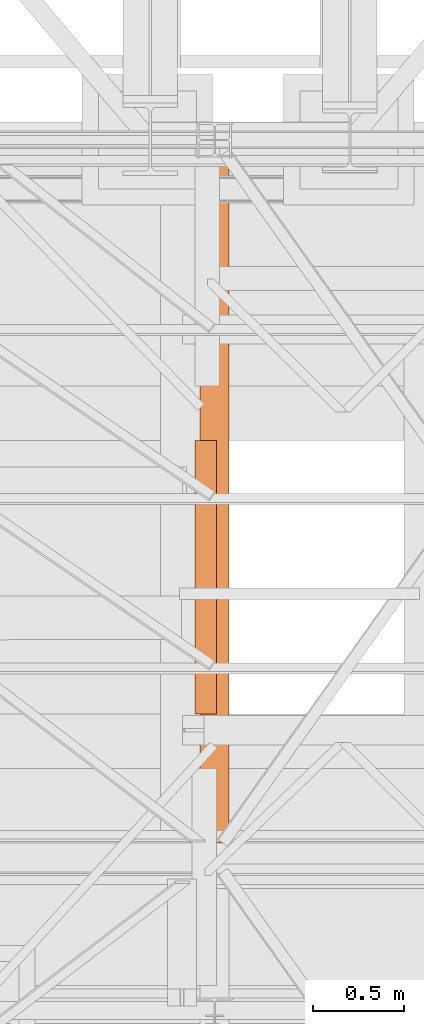
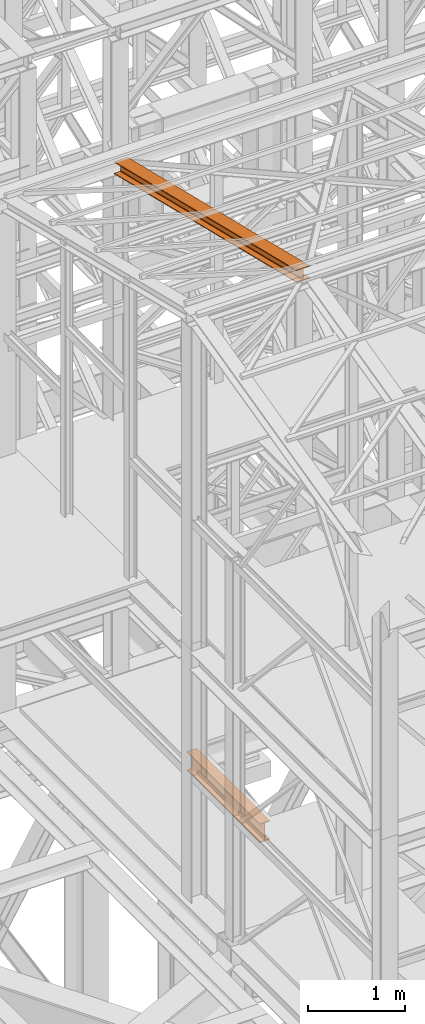
# One storey, part 28 of 208: 2 proxies.
"""IFC2X3 building model written with IfcOpenShell, lengths in millimetres."""

from ifc_helpers import new_model, entity, si_unit, converted_unit, frame, origin, origin_with_axes, place, context, subcontext, project, spatial, faceted_brep, element, save


model = new_model("IFC2X3")

# Units and contexts
model_context = context("Model", 3, precision=1e-05, world=origin())
plan_context = context("Plan", 3, precision=1e-05, world=origin())
body_context = subcontext(model_context, "Body", "Model", "MODEL_VIEW")
ifc_project = project(units=[si_unit("LENGTHUNIT", "METRE", prefix="MILLI"), converted_unit("PLANEANGLEUNIT", "DEGREE", entity("IfcPlaneAngleMeasure", 0.0174532925199433), si_unit("PLANEANGLEUNIT", "RADIAN"), dimensions=[0, 0, 0, 0, 0, 0, 0]), si_unit("AREAUNIT", "SQUARE_METRE"), si_unit("VOLUMEUNIT", "CUBIC_METRE")], contexts=[model_context, plan_context])

# Building, storey
building_placement = place(None, origin())
building = spatial("IfcBuilding", under=ifc_project, at=building_placement, CompositionType="COMPLEX")
storey_placement = place(building_placement, origin_with_axes())
storey = spatial("IfcBuildingStorey", under=building, at=storey_placement, Name="Geschoss", CompositionType="ELEMENT")

# Proxies
proxy_1_placement = place(storey_placement, frame((2468.254966591507, -21137.57438465545, 11628.70515179705), z_axis=(0.0, 0.0, 1.0), x_axis=(1.0, 0.0, 0.0)))
element("IfcBuildingElementProxy", 1, at=proxy_1_placement, inside=storey, context=body_context, shape_type="Brep", body=[
    faceted_brep([(160.0100113248891, 0.01000000000203727, 1074.775244917653), (0.01000000000567525, 0.01000000000203727, 1074.775244917653), (0.01000000000021828, 3780.009979404025, 156.4315054631916), (160.01001132488, 3780.009979404025, 156.4315054631916), (0.01000000000567525, 0.01000000000203727, 1074.775244917653), (0.01000000000567525, 0.01000000000203727, 1065.513442427271), (0.01000000000021828, 3780.009979404025, 147.1697029728093), (0.01000000000021828, 3780.009979404025, 156.4315054631916), (0.01000000000567525, 0.01000000000203727, 1065.513442427271), (62.01000457466125, 0.01000000000203727, 1065.513442427271), (62.01000457465671, 3780.009979404025, 147.1697029728093), (0.01000000000021828, 3780.009979404025, 147.1697029728093), (62.01000457466125, 0.01000000000203727, 1065.513442427271), (69.77318079978704, 0.01000000000203727, 1063.914455819968), (69.77318079977886, 3780.009979404025, 145.5707163655079), (62.01000457465671, 3780.009979404025, 147.1697029728093), (69.77318079978704, 0.01000000000203727, 1063.914455819968), (75.45621545821996, 0.01000000000203727, 1058.066108594254), (75.45621545821086, 3780.009979404025, 139.7223691397903), (69.77318079977886, 3780.009979404025, 145.5707163655079), (75.45621545821996, 0.01000000000203727, 1058.066108594254), (77.01000563636899, 0.01000000000203727, 1050.077113888498), (77.0100056363608, 3780.009979404025, 131.7333744340358), (75.45621545821086, 3780.009979404025, 139.7223691397903), (77.01000563636899, 0.01000000000203727, 1050.077113888498), (77.01000563636899, 0.01000000000203727, 943.0518743172743), (77.0100056363608, 3780.009979404025, 24.70813486281259), (77.0100056363608, 3780.009979404025, 131.7333744340358), (77.01000563636899, 0.01000000000203727, 943.0518743172743), (75.45621545821905, 0.01000000000203727, 935.0628757778613), (75.45621545821086, 3780.009979404025, 16.71913632339965), (77.0100056363608, 3780.009979404025, 24.70813486281259), (75.45621545821905, 0.01000000000203727, 935.0628757778613), (69.77318079978704, 0.01000000000203727, 929.2145285521474), (69.77318079977886, 3780.009979404025, 10.87078909768752), (75.45621545821086, 3780.009979404025, 16.71913632339965), (69.77318079978704, 0.01000000000203727, 929.2145285521474), (62.01000457466125, 0.01000000000203727, 927.6155419448442), (62.01000457465307, 3780.009979404025, 9.27180249038247), (69.77318079977886, 3780.009979404025, 10.87078909768752), (62.01000457466125, 0.01000000000203727, 927.6155419448442), (0.01000000000567525, 0.01000000000203727, 927.6155419448423), (0.01000000000021828, 3780.009979404025, 9.27180249038247), (62.01000457465307, 3780.009979404025, 9.27180249038247), (0.01000000000567525, 0.01000000000203727, 927.6155419448423), (0.01000000000476575, 0.01000000000203727, 918.3537394544601), (0.01000000000021828, 3780.009979404025, 0.01000000000021828), (0.01000000000021828, 3780.009979404025, 9.27180249038247), (0.01000000000476575, 0.01000000000203727, 918.3537394544601), (160.0100113248891, 0.01000000000203727, 918.3537394544619), (160.0100113248827, 3780.009979404025, 0.01000000000021828), (0.01000000000021828, 3780.009979404025, 0.01000000000021828), (160.0100113248891, 0.01000000000203727, 918.3537394544619), (160.0100113248891, 0.01000000000203727, 927.6155419448423), (160.0100113248836, 3780.009979404025, 9.27180249038065), (160.0100113248827, 3780.009979404025, 0.01000000000021828), (160.0100113248891, 0.01000000000203727, 927.6155419448423), (98.01000675023079, 0.01000000000203727, 927.6155419448423), (98.0100067502226, 3780.009979404025, 9.27180249038247), (160.0100113248836, 3780.009979404025, 9.27180249038065), (98.01000675023079, 0.01000000000203727, 927.6155419448423), (90.246830525105, 0.01000000000203727, 929.2145285521474), (90.24683052509681, 3780.009979404025, 10.87078909768752), (98.0100067502226, 3780.009979404025, 9.27180249038247), (90.246830525105, 0.01000000000203727, 929.2145285521474), (84.56379586667299, 0.01000000000203727, 935.0628757778613), (84.5637958666648, 3780.009979404025, 16.71913632339783), (90.24683052509681, 3780.009979404025, 10.87078909768752), (84.56379586667299, 0.01000000000203727, 935.0628757778613), (83.01000568852305, 0.01000000000203727, 943.0518743172743), (83.01000568851487, 3780.009979404025, 24.70813486281077), (84.5637958666648, 3780.009979404025, 16.71913632339783), (83.01000568852305, 0.01000000000203727, 943.0518743172743), (83.01000568852305, 0.01000000000203727, 1050.077113888496), (83.01000568851487, 3780.009979404025, 131.733374434034), (83.01000568851487, 3780.009979404025, 24.70813486281077), (83.01000568852305, 0.01000000000203727, 1050.077113888496), (84.5637958666739, 0.01000000000203727, 1058.066108594254), (84.5637958666648, 3780.009979404025, 139.7223691397903), (83.01000568851487, 3780.009979404025, 131.733374434034), (84.5637958666739, 0.01000000000203727, 1058.066108594254), (90.2468305251059, 0.01000000000203727, 1063.914455819968), (90.24683052509681, 3780.009979404025, 145.5707163655079), (84.5637958666648, 3780.009979404025, 139.7223691397903), (90.2468305251059, 0.01000000000203727, 1063.914455819968), (98.01000675023079, 0.01000000000203727, 1065.513442427271), (98.0100067502226, 3780.009979404025, 147.1697029728093), (90.24683052509681, 3780.009979404025, 145.5707163655079), (98.01000675023079, 0.01000000000203727, 1065.513442427271), (160.0100113248891, 0.01000000000203727, 1065.513442427271), (160.0100113248827, 3780.009979404025, 147.1697029728093), (98.0100067502226, 3780.009979404025, 147.1697029728093), (160.0100113248891, 0.01000000000203727, 1065.513442427271), (160.0100113248891, 0.01000000000203727, 1074.775244917653), (160.01001132488, 3780.009979404025, 156.4315054631916), (160.0100113248827, 3780.009979404025, 147.1697029728093), (0.01000000000567525, 0.01000000000203727, 1074.775244917653), (160.0100113248891, 0.01000000000203727, 1074.775244917653), (160.0100113248891, 0.01000000000203727, 1065.513442427271), (98.01000675023079, 0.01000000000203727, 1065.513442427271), (90.2468305251059, 0.01000000000203727, 1063.914455819968), (84.5637958666739, 0.01000000000203727, 1058.066108594254), (83.01000568852305, 0.01000000000203727, 1050.077113888496), (83.01000568852305, 0.01000000000203727, 943.0518743172743), (84.56379586667299, 0.01000000000203727, 935.0628757778613), (90.246830525105, 0.01000000000203727, 929.2145285521474), (98.01000675023079, 0.01000000000203727, 927.6155419448423), (160.0100113248891, 0.01000000000203727, 927.6155419448423), (160.0100113248891, 0.01000000000203727, 918.3537394544619), (0.01000000000476575, 0.01000000000203727, 918.3537394544601), (0.01000000000567525, 0.01000000000203727, 927.6155419448423), (62.01000457466125, 0.01000000000203727, 927.6155419448442), (69.77318079978704, 0.01000000000203727, 929.2145285521474), (75.45621545821905, 0.01000000000203727, 935.0628757778613), (77.01000563636899, 0.01000000000203727, 943.0518743172743), (77.01000563636899, 0.01000000000203727, 1050.077113888498), (75.45621545821996, 0.01000000000203727, 1058.066108594254), (69.77318079978704, 0.01000000000203727, 1063.914455819968), (62.01000457466125, 0.01000000000203727, 1065.513442427271), (0.01000000000567525, 0.01000000000203727, 1065.513442427271), (160.01001132488, 3780.009979404025, 156.4315054631916), (0.01000000000021828, 3780.009979404025, 156.4315054631916), (0.01000000000021828, 3780.009979404025, 147.1697029728093), (62.01000457465671, 3780.009979404025, 147.1697029728093), (69.77318079977886, 3780.009979404025, 145.5707163655079), (75.45621545821086, 3780.009979404025, 139.7223691397903), (77.0100056363608, 3780.009979404025, 131.7333744340358), (77.0100056363608, 3780.009979404025, 24.70813486281259), (75.45621545821086, 3780.009979404025, 16.71913632339965), (69.77318079977886, 3780.009979404025, 10.87078909768752), (62.01000457465307, 3780.009979404025, 9.27180249038247), (0.01000000000021828, 3780.009979404025, 9.27180249038247), (0.01000000000021828, 3780.009979404025, 0.01000000000021828), (160.0100113248827, 3780.009979404025, 0.01000000000021828), (160.0100113248836, 3780.009979404025, 9.27180249038065), (98.0100067502226, 3780.009979404025, 9.27180249038247), (90.24683052509681, 3780.009979404025, 10.87078909768752), (84.5637958666648, 3780.009979404025, 16.71913632339783), (83.01000568851487, 3780.009979404025, 24.70813486281077), (83.01000568851487, 3780.009979404025, 131.733374434034), (84.5637958666648, 3780.009979404025, 139.7223691397903), (90.24683052509681, 3780.009979404025, 145.5707163655079), (98.0100067502226, 3780.009979404025, 147.1697029728093), (160.0100113248827, 3780.009979404025, 147.1697029728093)], [[[0, 1, 2, 3]], [[4, 5, 6, 7]], [[8, 9, 10, 11]], [[12, 13, 14, 15]], [[16, 17, 18, 19]], [[20, 21, 22, 23]], [[24, 25, 26, 27]], [[28, 29, 30, 31]], [[32, 33, 34, 35]], [[36, 37, 38, 39]], [[40, 41, 42, 43]], [[44, 45, 46, 47]], [[48, 49, 50, 51]], [[52, 53, 54, 55]], [[56, 57, 58, 59]], [[60, 61, 62, 63]], [[64, 65, 66, 67]], [[68, 69, 70, 71]], [[72, 73, 74, 75]], [[76, 77, 78, 79]], [[80, 81, 82, 83]], [[84, 85, 86, 87]], [[88, 89, 90, 91]], [[92, 93, 94, 95]], [[96, 97, 98, 99, 100, 101, 102, 103, 104, 105, 106, 107, 108, 109, 110, 111, 112, 113, 114, 115, 116, 117, 118, 119]], [[120, 121, 122, 123, 124, 125, 126, 127, 128, 129, 130, 131, 132, 133, 134, 135, 136, 137, 138, 139, 140, 141, 142, 143]]], orient=[[False], [False], [False], [False], [False], [False], [False], [False], [False], [False], [False], [False], [False], [False], [False], [False], [False], [False], [False], [False], [False], [False], [False], [False], [False], [False]]),
])
proxy_2_placement = place(storey_placement, frame((2438.254968338675, -20428.57439012789, 5044.990005364415), z_axis=(0.0, 0.0, 1.0), x_axis=(1.0, 0.0, 0.0)))
element("IfcBuildingElementProxy", 2, at=proxy_2_placement, inside=storey, context=body_context, shape_type="Brep", body=[
    faceted_brep([(120.0100000000002, 1510.009999999998, 0.01000000000021828), (120.0100000000002, 0.00999999999839929, 0.01000000000021828), (120.0100000000002, 0.00999999999839929, 9.810000190735991), (120.0100000000002, 1510.009999999998, 9.810000190735082), (120.0100000000002, 1510.009999999998, 9.810000190735082), (120.0100000000002, 0.00999999999839929, 9.810000190735991), (78.10999990463279, 0.00999999999839929, 9.810000190735082), (78.10999990463279, 1510.009999999998, 9.810000190735082), (78.10999990463279, 1510.009999999998, 9.810000190735082), (78.10999990463279, 0.00999999999839929, 9.810000190735082), (74.22772724864444, 0.00999999999839929, 10.32115675322984), (74.22772724864444, 1510.009999999998, 10.32115675323075), (74.22772724864444, 1510.009999999998, 10.32115675323075), (74.22772724864444, 0.00999999999839929, 10.32115675322984), (70.61002177988667, 0.00999999999839929, 11.81965942306215), (70.61002177988667, 1510.009999999998, 11.81965942306215), (70.61002177988667, 1510.009999999998, 11.81965942306215), (70.61002177988667, 0.00999999999839929, 11.81965942306215), (67.5033981868346, 0.00999999999839929, 14.2033984729369), (67.5033981868346, 1510.009999999998, 14.2033984729369), (67.5033981868346, 1510.009999999998, 14.2033984729369), (67.5033981868346, 0.00999999999839929, 14.2033984729369), (65.11965913696076, 0.00999999999839929, 17.31002206598896), (65.11965913696076, 1510.009999999998, 17.31002206598896), (65.11965913696076, 1510.009999999998, 17.31002206598896), (65.11965913696076, 0.00999999999839929, 17.31002206598896), (63.62115646713028, 0.00999999999839929, 20.92772753474765), (63.62115646713028, 1510.009999999998, 20.92772753474765), (63.62115646713028, 1510.009999999998, 20.92772753474765), (63.62115646713028, 0.00999999999839929, 20.92772753474765), (63.10999990463279, 0.00999999999839929, 24.81000019073599), (63.10999990463279, 1510.009999999998, 24.81000019073508), (63.10999990463279, 1510.009999999998, 24.81000019073508), (63.10999990463279, 0.00999999999839929, 24.81000019073599), (63.10999990463279, 0.00999999999839929, 215.2099998092654), (63.10999990463279, 1510.009999999998, 215.2099998092654), (63.10999990463279, 1510.009999999998, 215.2099998092654), (63.10999990463279, 0.00999999999839929, 215.2099998092654), (63.62115646713028, 0.00999999999839929, 219.0922724652528), (63.62115646713028, 1510.009999999998, 219.0922724652519), (63.62115646713028, 1510.009999999998, 219.0922724652519), (63.62115646713028, 0.00999999999839929, 219.0922724652528), (65.11965913695985, 0.00999999999839929, 222.7099779340106), (65.11965913696076, 1510.009999999998, 222.7099779340106), (65.11965913696076, 1510.009999999998, 222.7099779340106), (65.11965913695985, 0.00999999999839929, 222.7099779340106), (67.5033981868346, 0.00999999999839929, 225.8166015270635), (67.5033981868346, 1510.009999999998, 225.8166015270635), (67.5033981868346, 1510.009999999998, 225.8166015270635), (67.5033981868346, 0.00999999999839929, 225.8166015270635), (70.61002177988667, 0.00999999999839929, 228.2003405769374), (70.61002177988667, 1510.009999999998, 228.2003405769374), (70.61002177988667, 1510.009999999998, 228.2003405769374), (70.61002177988667, 0.00999999999839929, 228.2003405769374), (74.22772724864444, 0.00999999999839929, 229.6988432467688), (74.22772724864444, 1510.009999999998, 229.6988432467688), (74.22772724864444, 1510.009999999998, 229.6988432467688), (74.22772724864444, 0.00999999999839929, 229.6988432467688), (78.10999990463279, 0.00999999999839929, 230.2099998092654), (78.10999990463279, 1510.009999999998, 230.2099998092654), (78.10999990463279, 1510.009999999998, 230.2099998092654), (78.10999990463279, 0.00999999999839929, 230.2099998092654), (120.0100000000002, 0.00999999999839929, 230.2099998092654), (120.0100000000002, 1510.009999999998, 230.2099998092654), (120.0100000000002, 1510.009999999998, 230.2099998092654), (120.0100000000002, 0.00999999999839929, 230.2099998092654), (120.0100000000002, 0.00999999999839929, 240.0100000000002), (120.0100000000002, 1510.009999999998, 240.0100000000002), (120.0100000000002, 1510.009999999998, 240.0100000000002), (120.0100000000002, 0.00999999999839929, 240.0100000000002), (0.01000000000021828, 0.00999999999839929, 240.0100000000002), (0.01000000000021828, 1510.009999999998, 240.0100000000002), (0.01000000000021828, 1510.009999999998, 240.0100000000002), (0.01000000000021828, 0.00999999999839929, 240.0100000000002), (0.01000000000021828, 0.00999999999839929, 230.2099998092654), (0.01000000000021828, 1510.009999999998, 230.2099998092654), (0.01000000000021828, 1510.009999999998, 230.2099998092654), (0.01000000000021828, 0.00999999999839929, 230.2099998092654), (41.91000009536765, 0.00999999999839929, 230.2099998092654), (41.91000009536765, 1510.009999999998, 230.2099998092654), (41.91000009536765, 1510.009999999998, 230.2099998092654), (41.91000009536765, 0.00999999999839929, 230.2099998092654), (45.792272751356, 0.00999999999839929, 229.6988432467688), (45.792272751356, 1510.009999999998, 229.6988432467688), (45.792272751356, 1510.009999999998, 229.6988432467688), (45.792272751356, 0.00999999999839929, 229.6988432467688), (49.40997822011377, 0.00999999999839929, 228.2003405769374), (49.40997822011377, 1510.009999999998, 228.2003405769374), (49.40997822011377, 1510.009999999998, 228.2003405769374), (49.40997822011377, 0.00999999999839929, 228.2003405769374), (52.51660181316584, 0.00999999999839929, 225.8166015270635), (52.51660181316584, 1510.009999999998, 225.8166015270635), (52.51660181316584, 1510.009999999998, 225.8166015270635), (52.51660181316584, 0.00999999999839929, 225.8166015270635), (54.90034086303967, 0.00999999999839929, 222.7099779340106), (54.90034086303967, 1510.009999999998, 222.7099779340106), (54.90034086303967, 1510.009999999998, 222.7099779340106), (54.90034086303967, 0.00999999999839929, 222.7099779340106), (56.39884353287016, 0.00999999999839929, 219.0922724652519), (56.39884353287016, 1510.009999999998, 219.0922724652519), (56.39884353287016, 1510.009999999998, 219.0922724652519), (56.39884353287016, 0.00999999999839929, 219.0922724652519), (56.91000009536765, 0.00999999999839929, 215.2099998092654), (56.91000009536765, 1510.009999999998, 215.2099998092654), (56.91000009536765, 1510.009999999998, 215.2099998092654), (56.91000009536765, 0.00999999999839929, 215.2099998092654), (56.91000009536765, 0.00999999999839929, 24.81000019073599), (56.91000009536765, 1510.009999999998, 24.81000019073508), (56.91000009536765, 1510.009999999998, 24.81000019073508), (56.91000009536765, 0.00999999999839929, 24.81000019073599), (56.17579672995453, 0.00999999999839929, 20.17476099858959), (56.17579672995453, 1510.009999999998, 20.17476099858959), (56.17579672995453, 1510.009999999998, 20.17476099858959), (56.17579672995453, 0.00999999999839929, 20.17476099858959), (54.0452364639259, 0.00999999999839929, 15.99323626528985), (54.0452364639259, 1510.009999999998, 15.99323626528985), (54.0452364639259, 1510.009999999998, 15.99323626528985), (54.0452364639259, 0.00999999999839929, 15.99323626528985), (50.72676402081379, 0.00999999999839929, 12.67476382217774), (50.72676402081379, 1510.009999999998, 12.67476382217774), (50.72676402081379, 1510.009999999998, 12.67476382217774), (50.72676402081379, 0.00999999999839929, 12.67476382217774), (46.54523928751405, 0.00999999999839929, 10.54420355614639), (46.54523928751405, 1510.009999999998, 10.54420355614639), (46.54523928751405, 1510.009999999998, 10.54420355614639), (46.54523928751405, 0.00999999999839929, 10.54420355614639), (41.91000009536765, 0.00999999999839929, 9.810000190735991), (41.91000009536765, 1510.009999999998, 9.810000190735082), (41.91000009536765, 1510.009999999998, 9.810000190735082), (41.91000009536765, 0.00999999999839929, 9.810000190735991), (0.01000000000021828, 0.00999999999839929, 9.810000190735082), (0.01000000000021828, 1510.009999999998, 9.810000190735082), (0.01000000000021828, 1510.009999999998, 9.810000190735082), (0.01000000000021828, 0.00999999999839929, 9.810000190735082), (0.01000000000021828, 0.00999999999839929, 0.01000000000021828), (0.01000000000021828, 1510.009999999998, 0.01000000000021828), (0.01000000000021828, 1510.009999999998, 0.01000000000021828), (0.01000000000021828, 0.00999999999839929, 0.01000000000021828), (120.0100000000002, 0.00999999999839929, 0.01000000000021828), (120.0100000000002, 1510.009999999998, 0.01000000000021828), (120.0100000000002, 0.00999999999839929, 0.01000000000021828), (0.01000000000021828, 0.00999999999839929, 0.01000000000021828), (0.01000000000021828, 0.00999999999839929, 9.810000190735082), (41.91000009536765, 0.00999999999839929, 9.810000190735991), (46.54523928751405, 0.00999999999839929, 10.54420355614639), (50.72676402081379, 0.00999999999839929, 12.67476382217774), (54.0452364639259, 0.00999999999839929, 15.99323626528985), (56.17579672995453, 0.00999999999839929, 20.17476099858959), (56.91000009536765, 0.00999999999839929, 24.81000019073599), (56.91000009536765, 0.00999999999839929, 215.2099998092654), (56.39884353287016, 0.00999999999839929, 219.0922724652519), (54.90034086303967, 0.00999999999839929, 222.7099779340106), (52.51660181316584, 0.00999999999839929, 225.8166015270635), (49.40997822011377, 0.00999999999839929, 228.2003405769374), (45.792272751356, 0.00999999999839929, 229.6988432467688), (41.91000009536765, 0.00999999999839929, 230.2099998092654), (0.01000000000021828, 0.00999999999839929, 230.2099998092654), (0.01000000000021828, 0.00999999999839929, 240.0100000000002), (120.0100000000002, 0.00999999999839929, 240.0100000000002), (120.0100000000002, 0.00999999999839929, 230.2099998092654), (78.10999990463279, 0.00999999999839929, 230.2099998092654), (74.22772724864444, 0.00999999999839929, 229.6988432467688), (70.61002177988667, 0.00999999999839929, 228.2003405769374), (67.5033981868346, 0.00999999999839929, 225.8166015270635), (65.11965913695985, 0.00999999999839929, 222.7099779340106), (63.62115646713028, 0.00999999999839929, 219.0922724652528), (63.10999990463279, 0.00999999999839929, 215.2099998092654), (63.10999990463279, 0.00999999999839929, 24.81000019073599), (63.62115646713028, 0.00999999999839929, 20.92772753474765), (65.11965913696076, 0.00999999999839929, 17.31002206598896), (67.5033981868346, 0.00999999999839929, 14.2033984729369), (70.61002177988667, 0.00999999999839929, 11.81965942306215), (74.22772724864444, 0.00999999999839929, 10.32115675322984), (78.10999990463279, 0.00999999999839929, 9.810000190735082), (120.0100000000002, 0.00999999999839929, 9.810000190735991), (120.0100000000002, 1510.009999999998, 9.810000190735082), (78.10999990463279, 1510.009999999998, 9.810000190735082), (74.22772724864444, 1510.009999999998, 10.32115675323075), (70.61002177988667, 1510.009999999998, 11.81965942306215), (67.5033981868346, 1510.009999999998, 14.2033984729369), (65.11965913696076, 1510.009999999998, 17.31002206598896), (63.62115646713028, 1510.009999999998, 20.92772753474765), (63.10999990463279, 1510.009999999998, 24.81000019073508), (63.10999990463279, 1510.009999999998, 215.2099998092654), (63.62115646713028, 1510.009999999998, 219.0922724652519), (65.11965913696076, 1510.009999999998, 222.7099779340106), (67.5033981868346, 1510.009999999998, 225.8166015270635), (70.61002177988667, 1510.009999999998, 228.2003405769374), (74.22772724864444, 1510.009999999998, 229.6988432467688), (78.10999990463279, 1510.009999999998, 230.2099998092654), (120.0100000000002, 1510.009999999998, 230.2099998092654), (120.0100000000002, 1510.009999999998, 240.0100000000002), (0.01000000000021828, 1510.009999999998, 240.0100000000002), (0.01000000000021828, 1510.009999999998, 230.2099998092654), (41.91000009536765, 1510.009999999998, 230.2099998092654), (45.792272751356, 1510.009999999998, 229.6988432467688), (49.40997822011377, 1510.009999999998, 228.2003405769374), (52.51660181316584, 1510.009999999998, 225.8166015270635), (54.90034086303967, 1510.009999999998, 222.7099779340106), (56.39884353287016, 1510.009999999998, 219.0922724652519), (56.91000009536765, 1510.009999999998, 215.2099998092654), (56.91000009536765, 1510.009999999998, 24.81000019073508), (56.17579672995453, 1510.009999999998, 20.17476099858959), (54.0452364639259, 1510.009999999998, 15.99323626528985), (50.72676402081379, 1510.009999999998, 12.67476382217774), (46.54523928751405, 1510.009999999998, 10.54420355614639), (41.91000009536765, 1510.009999999998, 9.810000190735082), (0.01000000000021828, 1510.009999999998, 9.810000190735082), (0.01000000000021828, 1510.009999999998, 0.01000000000021828), (120.0100000000002, 1510.009999999998, 0.01000000000021828)], [[[0, 1, 2, 3]], [[4, 5, 6, 7]], [[8, 9, 10, 11]], [[12, 13, 14, 15]], [[16, 17, 18, 19]], [[20, 21, 22, 23]], [[24, 25, 26, 27]], [[28, 29, 30, 31]], [[32, 33, 34, 35]], [[36, 37, 38, 39]], [[40, 41, 42, 43]], [[44, 45, 46, 47]], [[48, 49, 50, 51]], [[52, 53, 54, 55]], [[56, 57, 58, 59]], [[60, 61, 62, 63]], [[64, 65, 66, 67]], [[68, 69, 70, 71]], [[72, 73, 74, 75]], [[76, 77, 78, 79]], [[80, 81, 82, 83]], [[84, 85, 86, 87]], [[88, 89, 90, 91]], [[92, 93, 94, 95]], [[96, 97, 98, 99]], [[100, 101, 102, 103]], [[104, 105, 106, 107]], [[108, 109, 110, 111]], [[112, 113, 114, 115]], [[116, 117, 118, 119]], [[120, 121, 122, 123]], [[124, 125, 126, 127]], [[128, 129, 130, 131]], [[132, 133, 134, 135]], [[136, 137, 138, 139]], [[140, 141, 142, 143, 144, 145, 146, 147, 148, 149, 150, 151, 152, 153, 154, 155, 156, 157, 158, 159, 160, 161, 162, 163, 164, 165, 166, 167, 168, 169, 170, 171, 172, 173, 174]], [[175, 176, 177, 178, 179, 180, 181, 182, 183, 184, 185, 186, 187, 188, 189, 190, 191, 192, 193, 194, 195, 196, 197, 198, 199, 200, 201, 202, 203, 204, 205, 206, 207, 208, 209]]], orient=[[False], [False], [False], [False], [False], [False], [False], [False], [False], [False], [False], [False], [False], [False], [False], [False], [False], [False], [False], [False], [False], [False], [False], [False], [False], [False], [False], [False], [False], [False], [False], [False], [False], [False], [False], [False], [False]]),
])

save(model, "model.ifc")
